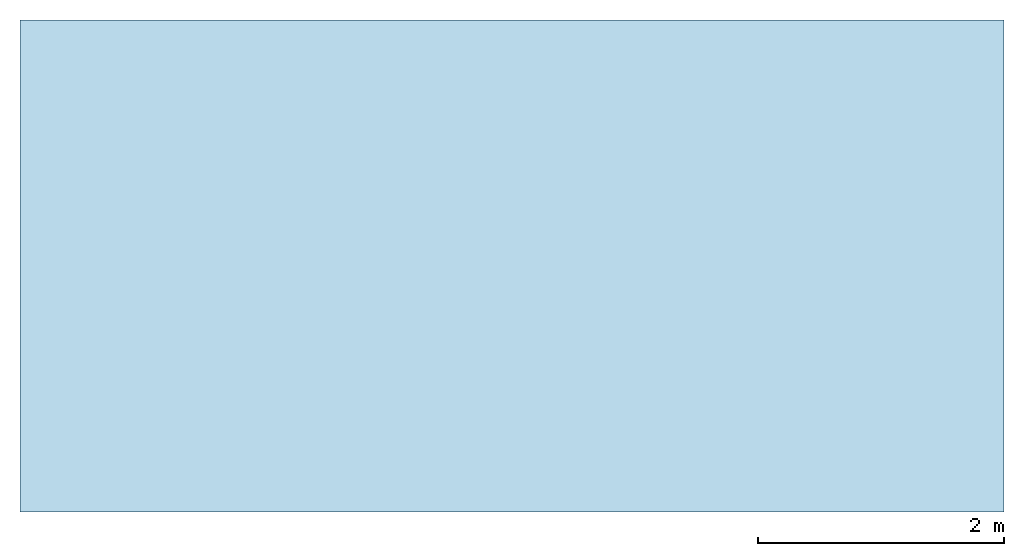
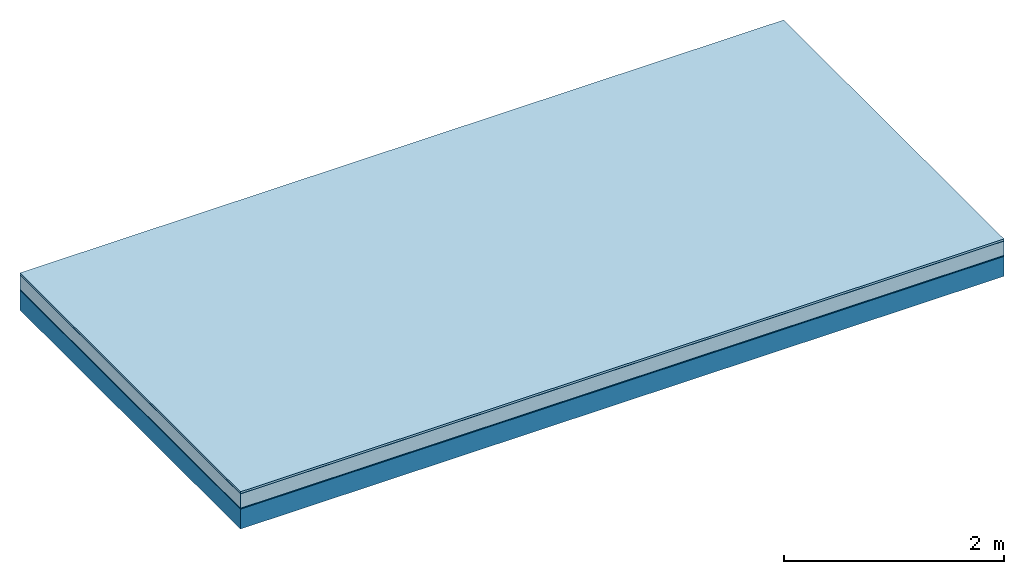
# One storey: 5 plates, 1 member, 1 element without a shape of its own.
"""IFC4 building model written with IfcOpenShell, lengths in metres."""

from ifc_helpers import new_model, si_unit, derived_unit, direction, frame, frame_2d, origin, origin_with_axes, place, context, project, spatial, rectangle, extrude, material, layer, layer_set, type_object, element, aggregate, save


model = new_model("IFC4")

# Units and contexts
plan_context = context("Plan", 3, precision=1e-05, world=origin(), true_north=direction((0.0, 1.0)))
model_context = context("Model", 3, precision=1e-05, world=origin(), true_north=direction((0.0, 1.0)))
ifc_project = project(units=[si_unit("LENGTHUNIT", "METRE"), derived_unit("SOUNDPRESSUREUNIT", [(si_unit("PRESSUREUNIT", "PASCAL", prefix="MICRO"), 0)]), si_unit("ENERGYUNIT", "JOULE", prefix="MEGA"), si_unit("MASSUNIT", "GRAM", prefix="KILO"), derived_unit("THERMALTRANSMITTANCEUNIT", [(si_unit("POWERUNIT", "WATT"), 1), (si_unit("AREAUNIT", "SQUARE_METRE"), -1), (si_unit("THERMODYNAMICTEMPERATUREUNIT", "KELVIN"), -1)]), derived_unit("AREADENSITYUNIT", [(si_unit("MASSUNIT", "GRAM", prefix="KILO"), 1), (si_unit("AREAUNIT", "SQUARE_METRE"), -1)]), derived_unit("USERDEFINED", [(si_unit("ENERGYUNIT", "JOULE", prefix="MEGA"), 1), (si_unit("AREAUNIT", "SQUARE_METRE"), -1)])], contexts=[plan_context, model_context])

# Site, building, storey
site = spatial("IfcSite", under=ifc_project)
building_placement = place(None, origin())
building = spatial("IfcBuilding", under=site, at=building_placement)
storey_placement = place(building_placement, origin())
storey = spatial("IfcBuildingStorey", under=building, at=storey_placement)

# Slab, member, plates
ifc_material_1 = material(Name="with tongue and groove", Category="07.009")
ifc_layer_1 = layer(ifc_material_1, 0.022, Name="Flooring")
ifc_material_2 = material(Category="09.006")
ifc_layer_2 = layer(ifc_material_2, 0.0005, Name="layer")
ifc_material_3 = material(Name="2x 60x80mm")
ifc_layer_3 = layer(ifc_material_3, 0.16, Name="On-material")
ifc_material_4 = material(Name="Wood fiber generic product", Category="10.009")
ifc_layer_4 = layer(ifc_material_4, 0.01, Name="Impact sound insulation")
ifc_material_5 = material(Name="protection", Category="09.007")
ifc_layer_5 = layer(ifc_material_5, 0.0005, Name="Sub-floor")
ifc_material_6 = material(Name="no composite action")
ifc_layer_6 = layer(ifc_material_6, 0.0, Name="Bond")
ifc_layer_7 = layer(None, 0.22, Name="Supporting structure")
ifc_layer_set = layer_set([ifc_layer_1, ifc_layer_2, ifc_layer_3, ifc_layer_4, ifc_layer_5, ifc_layer_6, ifc_layer_7])
slab_type = type_object("IfcSlabType", Name="A2029", PredefinedType="NOTDEFINED", material=ifc_layer_set)
slab_placement = place(None, frame((0.0, 0.0, 0.0), z_axis=(0.0, 0.0, -1.0), x_axis=(1.0, 0.0, 0.0)))
slab = element("IfcSlab", 1, at=slab_placement, inside=storey, type_object=slab_type, material=ifc_layer_set, Name="Slab #1")
ifc_material_7 = material(Name="Solid timber panel")
member_placement = place(slab_placement, origin())
member = element("IfcMember", 2, at=member_placement, material=ifc_material_7, Name="Supporting structure", context=plan_context, shape_type="SweptSolid", body=[
    extrude(rectangle(XDim=1.0, YDim=0.22, at=frame_2d((0.5, 0.11), x_axis=(1.0, 0.0))), frame((0.0, 4.0, 0.193), z_axis=(0.0, -1.0, 0.0), x_axis=(1.0, 0.0, 0.0)), (0.0, 0.0, 1.0), 4.0),
    extrude(rectangle(XDim=1.0, YDim=0.22, at=frame_2d((0.5, 0.11), x_axis=(1.0, 0.0))), frame((1.0, 4.0, 0.193), z_axis=(0.0, -1.0, 0.0), x_axis=(1.0, 0.0, 0.0)), (0.0, 0.0, 1.0), 4.0),
    extrude(rectangle(XDim=1.0, YDim=0.22, at=frame_2d((0.5, 0.11), x_axis=(1.0, 0.0))), frame((2.0, 4.0, 0.193), z_axis=(0.0, -1.0, 0.0), x_axis=(1.0, 0.0, 0.0)), (0.0, 0.0, 1.0), 4.0),
    extrude(rectangle(XDim=1.0, YDim=0.22, at=frame_2d((0.5, 0.11), x_axis=(1.0, 0.0))), frame((3.0, 4.0, 0.193), z_axis=(0.0, -1.0, 0.0), x_axis=(1.0, 0.0, 0.0)), (0.0, 0.0, 1.0), 4.0),
    extrude(rectangle(XDim=1.0, YDim=0.22, at=frame_2d((0.5, 0.11), x_axis=(1.0, 0.0))), frame((4.0, 4.0, 0.193), z_axis=(0.0, -1.0, 0.0), x_axis=(1.0, 0.0, 0.0)), (0.0, 0.0, 1.0), 4.0),
    extrude(rectangle(XDim=1.0, YDim=0.22, at=frame_2d((0.5, 0.11), x_axis=(1.0, 0.0))), frame((5.0, 4.0, 0.193), z_axis=(0.0, -1.0, 0.0), x_axis=(1.0, 0.0, 0.0)), (0.0, 0.0, 1.0), 4.0),
    extrude(rectangle(XDim=1.0, YDim=0.22, at=frame_2d((0.5, 0.11), x_axis=(1.0, 0.0))), frame((6.0, 4.0, 0.193), z_axis=(0.0, -1.0, 0.0), x_axis=(1.0, 0.0, 0.0)), (0.0, 0.0, 1.0), 4.0),
    extrude(rectangle(XDim=1.0, YDim=0.22, at=frame_2d((0.5, 0.11), x_axis=(1.0, 0.0))), frame((7.0, 4.0, 0.193), z_axis=(0.0, -1.0, 0.0), x_axis=(1.0, 0.0, 0.0)), (0.0, 0.0, 1.0), 4.0),
])
plate_1_placement = place(slab_placement, origin())
plate_1 = element("IfcPlate", 3, at=plate_1_placement, material=ifc_material_1, Name="Flooring", context=plan_context, shape_type="SweptSolid", body=[
    extrude(rectangle(XDim=8.0, YDim=4.0, at=frame_2d((4.0, 2.0), x_axis=(1.0, 0.0))), origin_with_axes(), (0.0, 0.0, 1.0), 0.022),
])
plate_2_placement = place(slab_placement, origin())
plate_2 = element("IfcPlate", 4, at=plate_2_placement, material=ifc_material_2, Name="layer", context=plan_context, shape_type="SweptSolid", body=[
    extrude(rectangle(XDim=8.0, YDim=4.0, at=frame_2d((4.0, 2.0), x_axis=(1.0, 0.0))), frame((0.0, 0.0, 0.022), z_axis=(0.0, 0.0, 1.0), x_axis=(1.0, 0.0, 0.0)), (0.0, 0.0, 1.0), 0.0005),
])
plate_3_placement = place(slab_placement, origin())
plate_3 = element("IfcPlate", 5, at=plate_3_placement, material=ifc_material_3, Name="On-material", context=plan_context, shape_type="SweptSolid", body=[
    extrude(rectangle(XDim=8.0, YDim=4.0, at=frame_2d((4.0, 2.0), x_axis=(1.0, 0.0))), frame((0.0, 0.0, 0.0225), z_axis=(0.0, 0.0, 1.0), x_axis=(1.0, 0.0, 0.0)), (0.0, 0.0, 1.0), 0.16),
])
plate_4_placement = place(slab_placement, origin())
plate_4 = element("IfcPlate", 6, at=plate_4_placement, material=ifc_material_4, Name="Impact sound insulation", context=plan_context, shape_type="SweptSolid", body=[
    extrude(rectangle(XDim=8.0, YDim=4.0, at=frame_2d((4.0, 2.0), x_axis=(1.0, 0.0))), frame((0.0, 0.0, 0.1825), z_axis=(0.0, 0.0, 1.0), x_axis=(1.0, 0.0, 0.0)), (0.0, 0.0, 1.0), 0.01),
])
plate_5_placement = place(slab_placement, origin())
plate_5 = element("IfcPlate", 7, at=plate_5_placement, material=ifc_material_5, Name="Sub-floor", context=plan_context, shape_type="SweptSolid", body=[
    extrude(rectangle(XDim=8.0, YDim=4.0, at=frame_2d((4.0, 2.0), x_axis=(1.0, 0.0))), frame((0.0, 0.0, 0.1925), z_axis=(0.0, 0.0, 1.0), x_axis=(1.0, 0.0, 0.0)), (0.0, 0.0, 1.0), 0.0005),
])
aggregate(slab, [plate_1, plate_2, plate_3, plate_4, plate_5, member])

save(model, "model.ifc")
